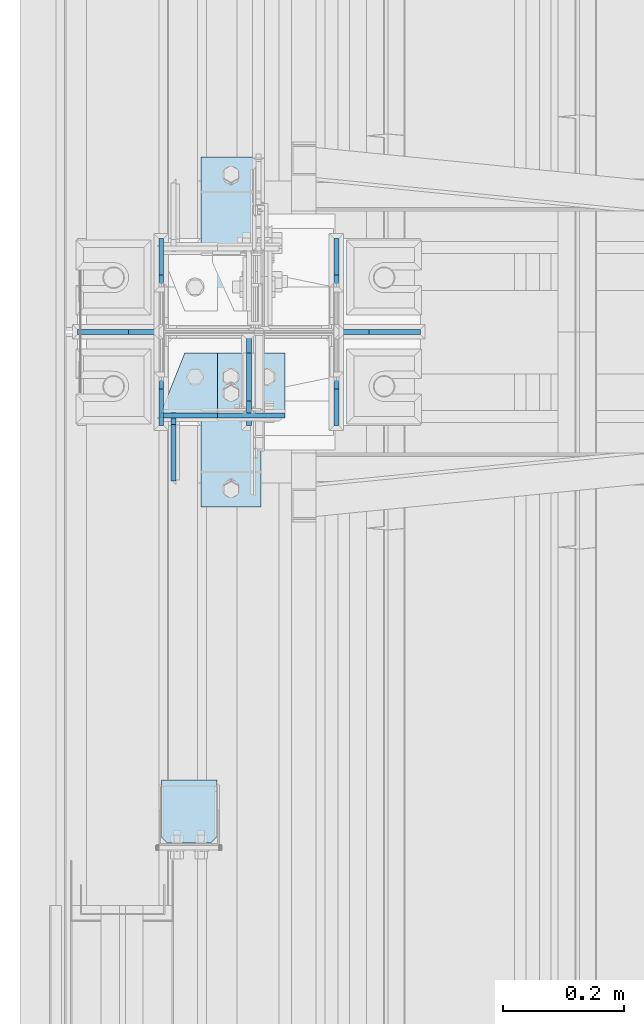
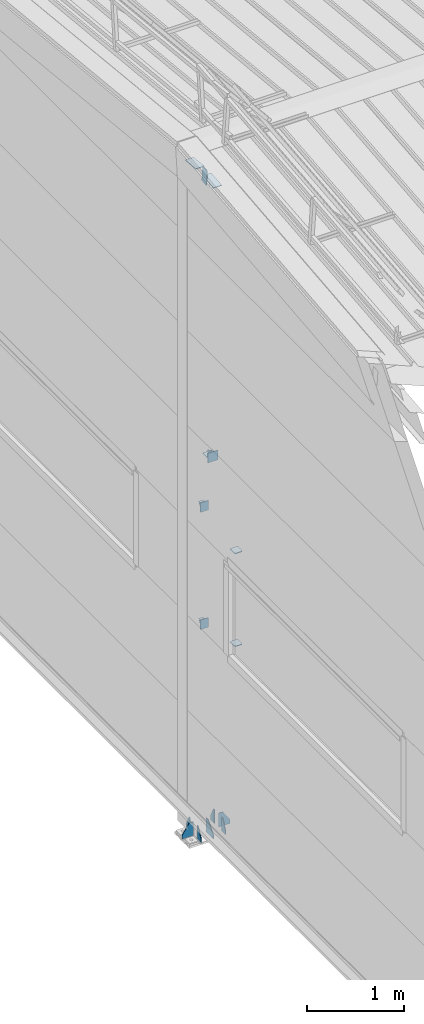
# One storey, part 116 of 709: 19 plates, 7 elements without a shape of their own.
"""IFC4 building model written with IfcOpenShell, lengths in millimetres."""

from ifc_helpers import new_model, si_unit, direction, frame, origin_with_axes, place, context, subcontext, project, spatial, line, indexed_curve, outline, extrude, material, element, aggregate, save


model = new_model("IFC4")

# Units and contexts
model_context = context("Model", 3, precision=0.2, world=origin_with_axes(), true_north=direction((0.0, 1.0)))
body_context = subcontext(model_context, "Body", "Model", "MODEL_VIEW")
ifc_project = project(units=[si_unit("LENGTHUNIT", "METRE", prefix="MILLI"), si_unit("AREAUNIT", "SQUARE_METRE"), si_unit("VOLUMEUNIT", "CUBIC_METRE"), si_unit("MASSUNIT", "GRAM", prefix="KILO"), si_unit("TIMEUNIT", "SECOND"), si_unit("PLANEANGLEUNIT", "RADIAN"), si_unit("SOLIDANGLEUNIT", "STERADIAN"), si_unit("THERMODYNAMICTEMPERATUREUNIT", "DEGREE_CELSIUS"), si_unit("LUMINOUSINTENSITYUNIT", "LUMEN")], contexts=[model_context])

# Site, building, storey
site_placement = place(None, origin_with_axes())
site = spatial("IfcSite", under=ifc_project, at=site_placement, CompositionType="ELEMENT")
building_placement = place(site_placement, origin_with_axes())
building = spatial("IfcBuilding", under=site, at=building_placement, Name="Undefined", CompositionType="ELEMENT")
storey_placement = place(building_placement, origin_with_axes())
storey = spatial("IfcBuildingStorey", under=building, at=storey_placement, Name="Undefined", CompositionType="ELEMENT", Elevation=0.0)

# Assembly, plates
assembly_1_placement = place(storey_placement, frame((149.0, 11000.0, -200.0), z_axis=(0.0, -1.0, 0.0), x_axis=(0.0, 0.0, 1.0)))
assembly_1 = element("IfcElementAssembly", 1, at=assembly_1_placement, inside=storey)
ifc_material = material(Name="C355-6", Category="STEEL")
plate_1_placement = place(assembly_1_placement, frame((25.0, 145.0, -74.5), z_axis=(0.0, -1.0, 0.0), x_axis=(0.0, 0.0, -1.0)))
plate_1 = element("IfcPlate", 2, at=plate_1_placement, material=ifc_material, ObjectType="426", context=body_context, shape_type="SolidModel", body=[
    extrude(outline(indexed_curve([(0.0, 0.0), (80.5, 0.0), (80.5, 50.0), (20.0, 175.0), (0.0, 175.0)], segments=[line(1, 2, 3, 4, 5, 1)])), frame((0.0, 0.0, 4.0), z_axis=(0.0, 0.0, 1.0), x_axis=(1.0, 0.0, 0.0)), (0.0, 0.0, -1.0), 8.0),
])
plate_2_placement = place(assembly_1_placement, frame((25.0, 0.0, 2.75), z_axis=(0.0, 1.0, 0.0), x_axis=(0.0, 0.0, 1.0)))
plate_2 = element("IfcPlate", 3, at=plate_2_placement, material=ifc_material, ObjectType="417", context=body_context, shape_type="SolidModel", body=[
    extrude(outline(indexed_curve([(0.0, 0.0), (152.25, 0.0), (152.25, 50.0), (50.0, 175.0), (0.0, 175.0)], segments=[line(1, 2, 3, 4, 5, 1)])), frame((0.0, 0.0, 4.0), z_axis=(0.0, 0.0, 1.0), x_axis=(1.0, 0.0, 0.0)), (0.0, 0.0, -1.0), 8.0),
])
plate_3_placement = place(assembly_1_placement, frame((25.0, 145.0, 74.5), z_axis=(0.0, 1.0, 0.0), x_axis=(0.0, 0.0, 1.0)))
plate_3 = element("IfcPlate", 4, at=plate_3_placement, material=ifc_material, ObjectType="426", context=body_context, shape_type="SolidModel", body=[
    extrude(outline(indexed_curve([(0.0, 0.0), (80.5, 0.0), (80.5, 50.0), (20.0, 175.0), (0.0, 175.0)], segments=[line(1, 2, 3, 4, 5, 1)])), frame((0.0, 0.0, 4.0), z_axis=(0.0, 0.0, 1.0), x_axis=(1.0, 0.0, 0.0)), (0.0, 0.0, -1.0), 8.0),
])
plate_4_placement = place(assembly_1_placement, frame((25.0, 149.0, 0.0), z_axis=(0.0, 0.0, -1.0), x_axis=(0.0, 1.0, 0.0)))
plate_4 = element("IfcPlate", 5, at=plate_4_placement, material=ifc_material, ObjectType="418", context=body_context, shape_type="SolidModel", body=[
    extrude(outline(indexed_curve([(0.0, 0.0), (135.0, 0.0), (135.0, 50.0), (50.0, 175.0), (0.0, 175.0)], segments=[line(1, 2, 3, 4, 5, 1)])), frame((0.0, 0.0, 4.0), z_axis=(0.0, 0.0, 1.0), x_axis=(1.0, 0.0, 0.0)), (0.0, 0.0, -1.0), 8.0),
])
plate_5_placement = place(assembly_1_placement, frame((25.0, -149.0, 0.0), z_axis=(0.0, 0.0, 1.0), x_axis=(0.0, -1.0, 0.0)))
plate_5 = element("IfcPlate", 6, at=plate_5_placement, material=ifc_material, ObjectType="418", context=body_context, shape_type="SolidModel", body=[
    extrude(outline(indexed_curve([(0.0, 0.0), (135.0, 0.0), (135.0, 50.0), (50.0, 175.0), (0.0, 175.0)], segments=[line(1, 2, 3, 4, 5, 1)])), frame((0.0, 0.0, 4.0), z_axis=(0.0, 0.0, 1.0), x_axis=(1.0, 0.0, 0.0)), (0.0, 0.0, -1.0), 8.0),
])
plate_6_placement = place(assembly_1_placement, frame((25.0, -145.0, -74.5), z_axis=(0.0, -1.0, 0.0), x_axis=(0.0, 0.0, -1.0)))
plate_6 = element("IfcPlate", 7, at=plate_6_placement, material=ifc_material, ObjectType="426", context=body_context, shape_type="SolidModel", body=[
    extrude(outline(indexed_curve([(0.0, 0.0), (80.5, 0.0), (80.5, 50.0), (20.0, 175.0), (0.0, 175.0)], segments=[line(1, 2, 3, 4, 5, 1)])), frame((0.0, 0.0, 4.0), z_axis=(0.0, 0.0, 1.0), x_axis=(1.0, 0.0, 0.0)), (0.0, 0.0, -1.0), 8.0),
])
plate_7_placement = place(assembly_1_placement, frame((25.0, -145.0, 74.5), z_axis=(0.0, 1.0, 0.0), x_axis=(0.0, 0.0, 1.0)))
plate_7 = element("IfcPlate", 8, at=plate_7_placement, material=ifc_material, ObjectType="426", context=body_context, shape_type="SolidModel", body=[
    extrude(outline(indexed_curve([(0.0, 0.0), (80.5, 0.0), (80.5, 50.0), (20.0, 175.0), (0.0, 175.0)], segments=[line(1, 2, 3, 4, 5, 1)])), frame((0.0, 0.0, 4.0), z_axis=(0.0, 0.0, 1.0), x_axis=(1.0, 0.0, 0.0)), (0.0, 0.0, -1.0), 8.0),
])
aggregate(assembly_1, [plate_1, plate_2, plate_3, plate_4, plate_5, plate_6, plate_7])

assembly_2_placement = place(storey_placement, frame((50.0, 11000.0, 2550.0), z_axis=(0.0, 0.0, -1.0), x_axis=(0.0, -1.0, 0.0)))
assembly_2 = element("IfcElementAssembly", 9, at=assembly_2_placement, inside=storey)
plate_8_placement = place(assembly_2_placement, frame((138.5, 47.0, -60.0), z_axis=(-1.0, 0.0, 0.0), x_axis=(0.0, -1.0, 0.0)))
plate_8 = element("IfcPlate", 10, at=plate_8_placement, material=ifc_material, ObjectType="501", context=body_context, shape_type="SolidModel", body=[
    extrude(outline(indexed_curve([(0.0, 0.0), (94.0, 0.0), (94.0, 120.0), (0.0, 120.0)], segments=[line(1, 2, 3, 4, 1)])), frame((0.0, 0.0, 4.0), z_axis=(0.0, 0.0, 1.0), x_axis=(1.0, 0.0, 0.0)), (0.0, 0.0, -1.0), 8.0),
])
plate_9_placement = place(assembly_2_placement, frame((34.5, 47.0, 0.0), z_axis=(0.0, 0.0, 1.0), x_axis=(0.0, -1.0, 0.0)))
plate_9 = element("IfcPlate", 11, at=plate_9_placement, material=ifc_material, ObjectType="502", context=body_context, shape_type="SolidModel", body=[
    extrude(outline(indexed_curve([(0.0, 100.0), (40.0, 0.0), (94.0, 0.0), (94.0, 100.0), (0.0, 100.0)], segments=[line(1, 2, 3, 4, 5, 1)])), frame((0.0, 0.0, 4.0), z_axis=(0.0, 0.0, 1.0), x_axis=(1.0, 0.0, 0.0)), (0.0, 0.0, -1.0), 8.0),
])
aggregate(assembly_2, [plate_8, plate_9])

assembly_3_placement = place(storey_placement, frame((50.0, 11000.0, 4020.0), z_axis=(0.0, 0.0, -1.0), x_axis=(0.0, -1.0, 0.0)))
assembly_3 = element("IfcElementAssembly", 12, at=assembly_3_placement, inside=storey)
plate_10_placement = place(assembly_3_placement, frame((34.5, 47.0, 0.0), z_axis=(0.0, 0.0, 1.0), x_axis=(0.0, -1.0, 0.0)))
plate_10 = element("IfcPlate", 13, at=plate_10_placement, material=ifc_material, ObjectType="502", context=body_context, shape_type="SolidModel", body=[
    extrude(outline(indexed_curve([(0.0, 100.0), (40.0, 0.0), (94.0, 0.0), (94.0, 100.0), (0.0, 100.0)], segments=[line(1, 2, 3, 4, 5, 1)])), frame((0.0, 0.0, 4.0), z_axis=(0.0, 0.0, 1.0), x_axis=(1.0, 0.0, 0.0)), (0.0, 0.0, -1.0), 8.0),
])
plate_11_placement = place(assembly_3_placement, frame((138.5, 47.0, -60.0), z_axis=(-1.0, 0.0, 0.0), x_axis=(0.0, -1.0, 0.0)))
plate_11 = element("IfcPlate", 14, at=plate_11_placement, material=ifc_material, ObjectType="501", context=body_context, shape_type="SolidModel", body=[
    extrude(outline(indexed_curve([(0.0, 0.0), (94.0, 0.0), (94.0, 120.0), (0.0, 120.0)], segments=[line(1, 2, 3, 4, 1)])), frame((0.0, 0.0, 4.0), z_axis=(0.0, 0.0, 1.0), x_axis=(1.0, 0.0, 0.0)), (0.0, 0.0, -1.0), 8.0),
])
aggregate(assembly_3, [plate_10, plate_11])

assembly_4_placement = place(storey_placement, frame((50.0, 10200.0, 2600.0), z_axis=(0.0, -1.0, 0.0), x_axis=(0.0, 0.0, 1.0)))
assembly_4 = element("IfcElementAssembly", 15, at=assembly_4_placement, inside=storey)
plate_12_placement = place(assembly_4_placement, frame((103.0, -46.0, 46.0), z_axis=(-1.0, 0.0, 0.0), x_axis=(0.0, 1.0, 0.0)))
plate_12 = element("IfcPlate", 16, at=plate_12_placement, material=ifc_material, ObjectType="510", context=body_context, shape_type="SolidModel", body=[
    extrude(outline(indexed_curve([(0.0, 10.0), (10.0, 0.0), (82.0, 0.0), (92.0, 10.0), (92.0, 104.0), (0.0, 104.0)], segments=[line(1, 2, 3, 4, 5, 6, 1)])), frame((0.0, 0.0, 4.0), z_axis=(0.0, 0.0, 1.0), x_axis=(1.0, 0.0, 0.0)), (0.0, 0.0, -1.0), 8.0),
])
plate_13_placement = place(assembly_4_placement, frame((1267.0, 46.0, 46.0), z_axis=(1.0, 0.0, 0.0), x_axis=(0.0, -1.0, 0.0)))
plate_13 = element("IfcPlate", 17, at=plate_13_placement, material=ifc_material, ObjectType="510", context=body_context, shape_type="SolidModel", body=[
    extrude(outline(indexed_curve([(0.0, 10.0), (10.0, 0.0), (82.0, 0.0), (92.0, 10.0), (92.0, 104.0), (0.0, 104.0)], segments=[line(1, 2, 3, 4, 5, 6, 1)])), frame((0.0, 0.0, 4.0), z_axis=(0.0, 0.0, 1.0), x_axis=(1.0, 0.0, 0.0)), (0.0, 0.0, -1.0), 8.0),
])
aggregate(assembly_4, [plate_12, plate_13])

assembly_5_placement = place(storey_placement, frame((149.0, 11000.0, 4610.0), z_axis=(0.0, 0.0, -1.0), x_axis=(0.0, -1.0, 0.0)))
assembly_5 = element("IfcElementAssembly", 18, at=assembly_5_placement, inside=storey)
plate_14_placement = place(assembly_5_placement, frame((34.5, 60.0, 0.0), z_axis=(0.0, 0.0, 1.0), x_axis=(0.0, -1.0, 0.0)))
plate_14 = element("IfcPlate", 19, at=plate_14_placement, material=ifc_material, ObjectType="507", context=body_context, shape_type="SolidModel", body=[
    extrude(outline(indexed_curve([(0.0, 0.0), (120.0, 0.0), (120.0, 100.0), (0.0, 100.0)], segments=[line(1, 2, 3, 4, 1)])), frame((0.0, 0.0, 4.0), z_axis=(0.0, 0.0, 1.0), x_axis=(1.0, 0.0, 0.0)), (0.0, 0.0, -1.0), 8.0),
])
plate_15_placement = place(assembly_5_placement, frame((138.5, 60.0, 60.0), z_axis=(-1.0, 0.0, 0.0), x_axis=(0.0, 0.0, -1.0)))
plate_15 = element("IfcPlate", 20, at=plate_15_placement, material=ifc_material, ObjectType="506", context=body_context, shape_type="SolidModel", body=[
    extrude(outline(indexed_curve([(0.0, 0.0), (120.0, 0.0), (120.0, 120.0), (0.0, 120.0)], segments=[line(1, 2, 3, 4, 1)])), frame((0.0, 0.0, 4.0), z_axis=(0.0, 0.0, 1.0), x_axis=(1.0, 0.0, 0.0)), (0.0, 0.0, -1.0), 8.0),
])
plate_16_placement = place(assembly_5_placement, frame((34.5, 0.0, -60.0), z_axis=(0.0, 1.0, 0.0), x_axis=(0.0, 0.0, 1.0)))
plate_16 = element("IfcPlate", 21, at=plate_16_placement, material=ifc_material, ObjectType="508", context=body_context, shape_type="SolidModel", body=[
    extrude(outline(indexed_curve([(0.0, 80.0), (36.0, 0.0), (56.0, 0.0), (56.0, 90.0), (46.0, 100.0), (0.0, 100.0)], segments=[line(1, 2, 3, 4, 5, 6, 1)])), frame((0.0, 0.0, 4.0), z_axis=(0.0, 0.0, 1.0), x_axis=(1.0, 0.0, 0.0)), (0.0, 0.0, -1.0), 8.0),
])
aggregate(assembly_5, [plate_14, plate_15, plate_16])

assembly_6_placement = place(storey_placement, frame((0.0, 10809.95037, 8209.41925), z_axis=(0.0, 0.9950371902, 0.099503719), x_axis=(1.0, 0.0, 0.0)))
assembly_6 = element("IfcElementAssembly", 22, at=assembly_6_placement, inside=storey)
plate_17_placement = place(assembly_6_placement, frame((169.5, 103.9603, 110.0), z_axis=(0.0, -1.0, 0.0), x_axis=(-1.0, 0.0, 0.0)))
plate_17 = element("IfcPlate", 23, at=plate_17_placement, material=ifc_material, ObjectType="591", context=body_context, shape_type="SolidModel", body=[
    extrude(outline(indexed_curve([(0.0, 0.0), (100.0, 0.0), (100.0, 220.0), (0.0, 220.0)], segments=[line(1, 2, 3, 4, 1)])), frame((0.0, 0.0, 4.0), z_axis=(0.0, 0.0, 1.0), x_axis=(1.0, 0.0, 0.0)), (0.0, 0.0, -1.0), 8.0),
])
plate_18_placement = place(assembly_6_placement, frame((24.0, 97.0, 47.0), z_axis=(-1.0, 0.0, 0.0), x_axis=(0.0, 0.0, -1.0)))
plate_18 = element("IfcPlate", 24, at=plate_18_placement, material=ifc_material, ObjectType="592", context=body_context, shape_type="SolidModel", body=[
    extrude(outline(indexed_curve([(0.0, 0.0), (94.0, 0.0), (94.0, 194.0), (0.0, 194.0)], segments=[line(1, 2, 3, 4, 1)])), frame((0.0, 0.0, 4.0), z_axis=(0.0, 0.0, 1.0), x_axis=(1.0, 0.0, 0.0)), (0.0, 0.0, -1.0), 8.0),
])
aggregate(assembly_6, [plate_17, plate_18])

# Assembly, plate
assembly_7_placement = place(storey_placement, frame((4000.0, 11190.04963, 8209.41925), z_axis=(0.0, -0.9950371902, 0.099503719), x_axis=(-1.0, 0.0, 0.0)))
assembly_7 = element("IfcElementAssembly", 25, at=assembly_7_placement, inside=storey)
plate_19_placement = place(assembly_7_placement, frame((3930.5, 103.9603, 110.0), z_axis=(0.0, -1.0, 0.0), x_axis=(-1.0, 0.0, 0.0)))
plate_19 = element("IfcPlate", 26, at=plate_19_placement, material=ifc_material, ObjectType="591", context=body_context, shape_type="SolidModel", body=[
    extrude(outline(indexed_curve([(0.0, 0.0), (100.0, 0.0), (100.0, 220.0), (0.0, 220.0)], segments=[line(1, 2, 3, 4, 1)])), frame((0.0, 0.0, 4.0), z_axis=(0.0, 0.0, 1.0), x_axis=(1.0, 0.0, 0.0)), (0.0, 0.0, -1.0), 8.0),
])
aggregate(assembly_7, [plate_19])

save(model, "model.ifc")
